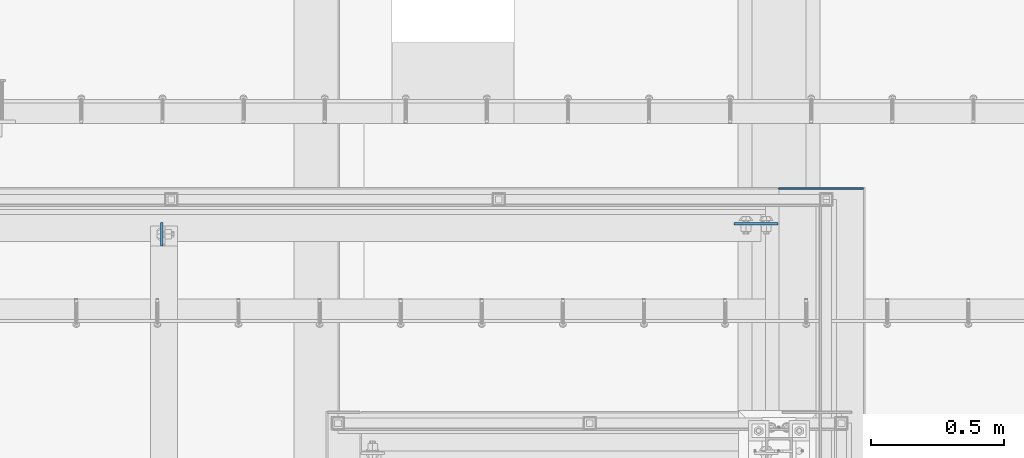
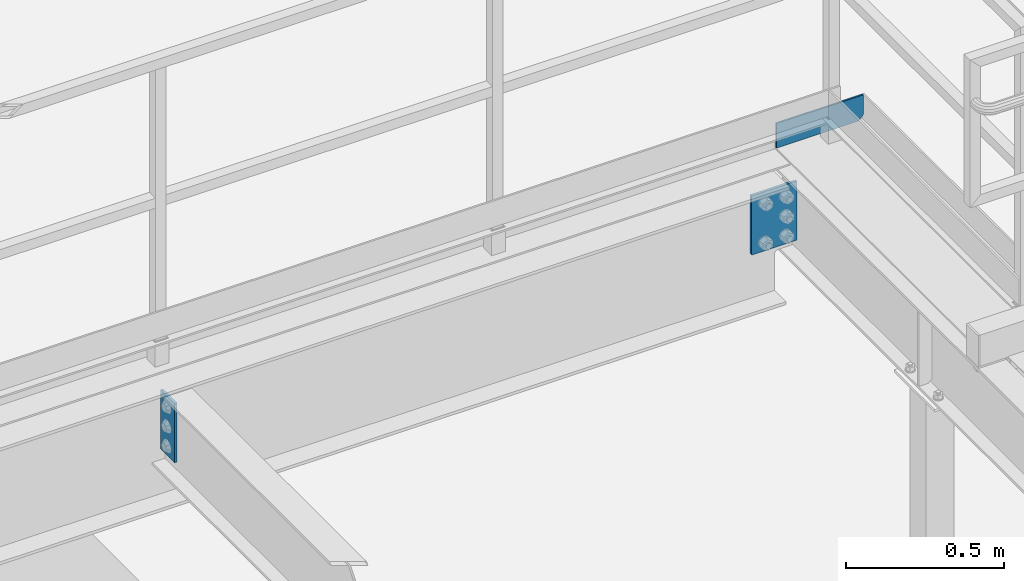
# One storey, part 3162 of 3843: 3 plates, 2 elements without a shape of their own.
"""IFC2X3 building model written with IfcOpenShell, lengths in millimetres."""

from ifc_helpers import new_model, si_unit, frame, origin_with_axes, place, context, subcontext, project, spatial, faceted_brep, material, type_object, element, aggregate, save


model = new_model("IFC2X3")

# Units and contexts
model_context = context("Model", 3, precision=1e-05, world=origin_with_axes())
body_context = subcontext(model_context, "Body", "Model", "MODEL_VIEW")
ifc_project = project(units=[si_unit("LENGTHUNIT", "METRE", prefix="MILLI"), si_unit("AREAUNIT", "SQUARE_METRE"), si_unit("VOLUMEUNIT", "CUBIC_METRE"), si_unit("MASSUNIT", "GRAM", prefix="KILO"), si_unit("TIMEUNIT", "SECOND"), si_unit("PLANEANGLEUNIT", "RADIAN"), si_unit("SOLIDANGLEUNIT", "STERADIAN"), si_unit("THERMODYNAMICTEMPERATUREUNIT", "DEGREE_CELSIUS"), si_unit("LUMINOUSINTENSITYUNIT", "LUMEN")], contexts=[model_context])

# Site, building, storey
site_placement = place(None, origin_with_axes())
site = spatial("IfcSite", under=ifc_project, at=site_placement, CompositionType="ELEMENT")
building_placement = place(site_placement, origin_with_axes())
building = spatial("IfcBuilding", under=site, at=building_placement, Name="Undefined", CompositionType="ELEMENT")
storey_placement = place(building_placement, origin_with_axes())
storey = spatial("IfcBuildingStorey", under=building, at=storey_placement, Name="Undefined", CompositionType="ELEMENT", Elevation=0.0)

# Assembly, plate
assembly_1_placement = place(storey_placement, origin_with_axes())
assembly_1 = element("IfcElementAssembly", 1, at=assembly_1_placement, inside=storey, Name="BEAM", AssemblyPlace="NOTDEFINED", PredefinedType="RIGID_FRAME")
ifc_material_1 = material(Name="STEEL/A572-50")
plate_type_1 = type_object("IfcPlateType", PredefinedType="NOTDEFINED")
plate_1_placement = place(assembly_1_placement, frame((53611.4625, 28456.73125, 33159.6999999995), z_axis=(0.0, -1.0, 0.0), x_axis=(0.0, 0.0, -1.0)))
plate_1 = element("IfcPlate", 2, at=plate_1_placement, type_object=plate_type_1, material=ifc_material_1, Name="PLATE", context=body_context, shape_type="Brep", body=[
    faceted_brep([(0.0, -4.76249999999709, 0.0), (0.0, -4.76249999999709, 88.9000015258789), (0.0, 4.76249999999709, 88.9000015258789), (0.0, 4.76249999999709, 0.0), (228.600006102781, -4.7625000004191, 88.9000015257589), (228.600006102781, 4.76249999954598, 88.9000015257443), (228.600006103079, -4.7625000004482, 7.27595761418343e-12), (228.600006103079, 4.76249999954598, -7.27595761418343e-12)], [[[0, 1, 2, 3]], [[1, 4, 5, 2]], [[4, 6, 7, 5]], [[6, 0, 3, 7]], [[5, 7, 3, 2]], [[6, 4, 1, 0]]]),
])
aggregate(assembly_1, [plate_1])

# Assembly, plates
assembly_2_placement = place(storey_placement, origin_with_axes())
assembly_2 = element("IfcElementAssembly", 3, at=assembly_2_placement, inside=storey, Name="BEAM", AssemblyPlace="NOTDEFINED", PredefinedType="RIGID_FRAME")
ifc_material_2 = material(Name="STEEL/A36")
plate_type_2 = type_object("IfcPlateType", PredefinedType="NOTDEFINED")
plate_2_placement = place(assembly_2_placement, frame((55930.8, 28584.525, 33204.1499999995), z_axis=(0.0, 0.0, 1.0), x_axis=(1.0, 0.0, 0.0)))
plate_2 = element("IfcPlate", 4, at=plate_2_placement, type_object=plate_type_2, material=ifc_material_2, Name="PLATE", context=body_context, shape_type="Brep", body=[
    faceted_brep([(0.0, -3.17499999999927, 0.0), (0.0, -3.17499999999927, 95.25), (-2.44140610448085e-05, 3.17500000000291, 95.2499999999927), (0.0, 3.17499999999927, 0.0), (317.5, -3.17499999999927, 95.25), (317.5, 3.17499999999927, 95.25), (317.5, -3.17499999999927, 19.0499992370605), (317.5, 3.17499999999927, 19.0499992370605), (298.450000762939, -3.17499999999927, 0.0), (298.450000762939, 3.17499999999927, 0.0)], [[[0, 1, 2, 3]], [[1, 4, 5, 2]], [[4, 6, 7, 5]], [[6, 8, 9, 7]], [[8, 0, 3, 9]], [[5, 7, 9, 3, 2]], [[8, 6, 4, 1, 0]]]),
])
plate_type_3 = type_object("IfcPlateType", PredefinedType="NOTDEFINED")
plate_3_placement = place(assembly_2_placement, frame((55927.625, 28451.96875, 33159.7), z_axis=(-1.0, 0.0, 0.0), x_axis=(0.0, 0.0, -1.0)))
plate_3 = element("IfcPlate", 5, at=plate_3_placement, type_object=plate_type_3, material=ifc_material_1, Name="PLATE", context=body_context, shape_type="Brep", body=[
    faceted_brep([(0.0, -4.76249999999709, 0.0), (0.0, -4.76249999999709, 165.100000000006), (0.0, 4.76249999999709, 165.100000000006), (0.0, 4.76249999999709, 0.0), (228.599999999999, -4.76250000000073, 165.099999526887), (228.599999999999, 4.76250000000073, 165.099999526887), (228.600006103079, -4.7625000004482, 7.27595761418343e-12), (228.600006103079, 4.76249999954598, -7.27595761418343e-12)], [[[0, 1, 2, 3]], [[1, 4, 5, 2]], [[4, 6, 7, 5]], [[6, 0, 3, 7]], [[5, 7, 3, 2]], [[6, 4, 1, 0]]]),
])
aggregate(assembly_2, [plate_2, plate_3])

save(model, "model.ifc")
